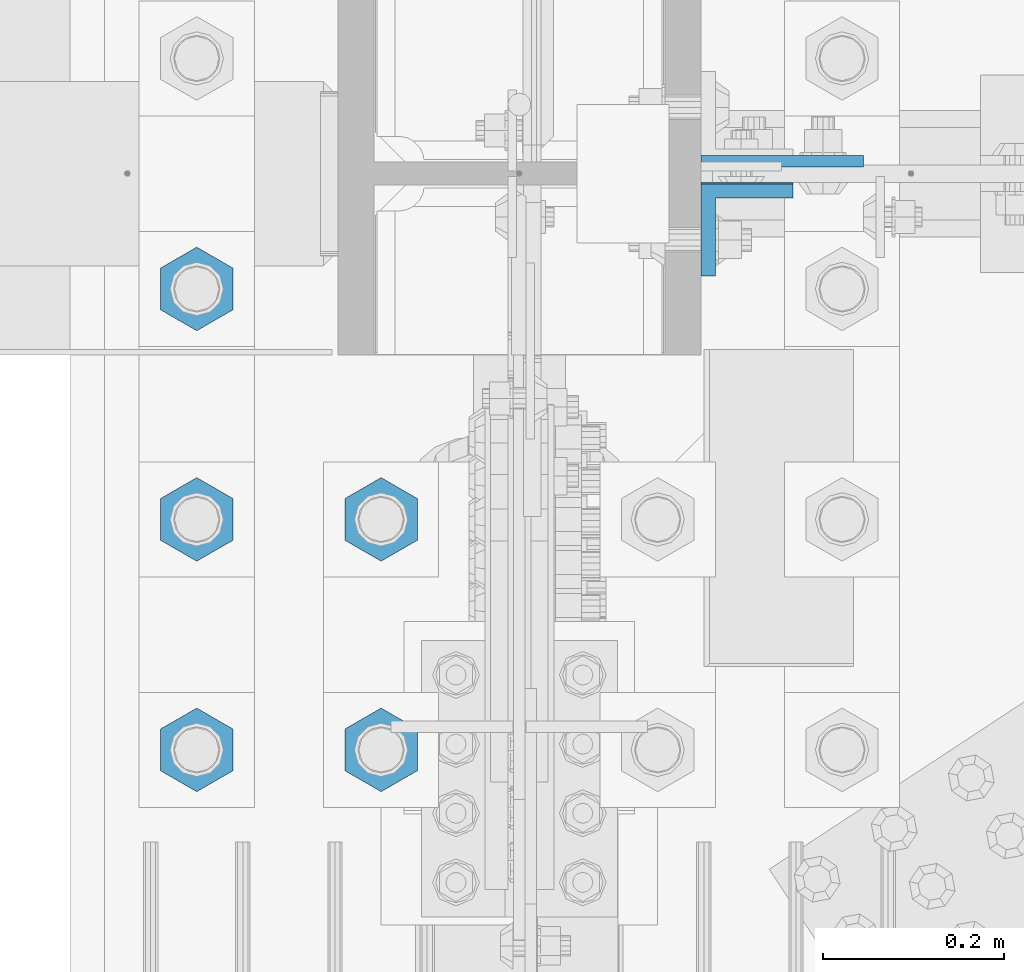
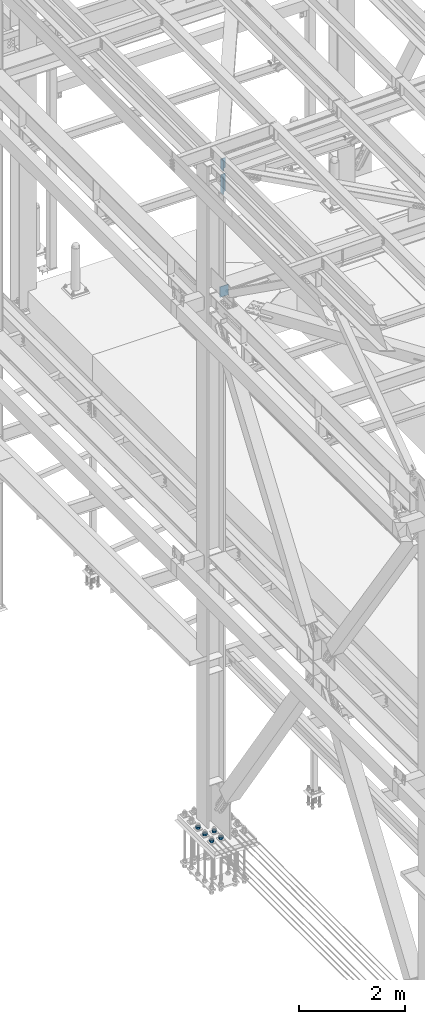
# One storey, part 1553 of 3843: 8 columns, 3 elements without a shape of their own.
"""IFC2X3 building model written with IfcOpenShell, lengths in millimetres."""

from ifc_helpers import new_model, si_unit, frame, origin_with_axes, place, context, subcontext, project, spatial, faceted_brep, material, type_object, element, aggregate, save


model = new_model("IFC2X3")

# Units and contexts
model_context = context("Model", 3, precision=1e-05, world=origin_with_axes())
body_context = subcontext(model_context, "Body", "Model", "MODEL_VIEW")
ifc_project = project(units=[si_unit("LENGTHUNIT", "METRE", prefix="MILLI"), si_unit("AREAUNIT", "SQUARE_METRE"), si_unit("VOLUMEUNIT", "CUBIC_METRE"), si_unit("MASSUNIT", "GRAM", prefix="KILO"), si_unit("TIMEUNIT", "SECOND"), si_unit("PLANEANGLEUNIT", "RADIAN"), si_unit("SOLIDANGLEUNIT", "STERADIAN"), si_unit("THERMODYNAMICTEMPERATUREUNIT", "DEGREE_CELSIUS"), si_unit("LUMINOUSINTENSITYUNIT", "LUMEN")], contexts=[model_context])

# Site, building, storey
site_placement = place(None, origin_with_axes())
site = spatial("IfcSite", under=ifc_project, at=site_placement, CompositionType="ELEMENT")
building_placement = place(site_placement, origin_with_axes())
building = spatial("IfcBuilding", under=site, at=building_placement, Name="Undefined", CompositionType="ELEMENT")
storey_placement = place(building_placement, origin_with_axes())
storey = spatial("IfcBuildingStorey", under=building, at=storey_placement, Name="Undefined", CompositionType="ELEMENT", Elevation=0.0)

# Assembly, columns
assembly_1_placement = place(storey_placement, origin_with_axes())
assembly_1 = element("IfcElementAssembly", 1, at=assembly_1_placement, inside=storey, Name="BEAM", AssemblyPlace="NOTDEFINED", PredefinedType="RIGID_FRAME")
ifc_material = material(Name="STEEL/A572-50")
column_type_1 = type_object("IfcColumnType", Name="L4X4X5/8", PredefinedType="NOTDEFINED")
column_1_placement = place(assembly_1_placement, frame((36826.8249999923, 75566.5879995346, 45113.5417966023), z_axis=(0.0, -1.0, 0.0), x_axis=(0.0, 0.0, 1.0)))
column_1 = element("IfcColumn", 2, at=column_1_placement, type_object=column_type_1, material=ifc_material, Name="ANGLE", ObjectType="L4X4X5/8", context=body_context, shape_type="Brep", body=[
    faceted_brep([(0.0, 50.8000000000029, -50.8000000000029), (0.0, 50.8000000000029, 50.8000000000029), (228.611761594606, 50.8000000000029, 50.8000000000029), (228.611761594606, 50.8000000000029, -50.8000000000029), (0.0, 34.9250000000029, 50.8000000000029), (228.611761594606, 34.9250000000029, 50.8000000000029), (0.0, 34.9250000000029, -34.9250000000029), (228.611761594606, 34.9250000000029, -34.9250000000029), (0.0, -50.8000000000029, -34.9250000000029), (228.611761594606, -50.8000000000029, -34.9250000000029), (0.0, -50.8000000000029, -50.8000000000029), (228.611761594606, -50.8000000000029, -50.8000000000029)], [[[0, 1, 2, 3]], [[1, 4, 5, 2]], [[4, 6, 7, 5]], [[6, 8, 9, 7]], [[8, 10, 11, 9]], [[10, 0, 3, 11]], [[5, 7, 9, 11, 3, 2]], [[10, 8, 6, 4, 1, 0]]]),
])
column_2_placement = place(assembly_1_placement, frame((36826.8249999969, 75568.1750003815, 44571.6187929595), z_axis=(0.0, -1.0, 0.0), x_axis=(0.0, 0.0, 1.0)))
column_2 = element("IfcColumn", 3, at=column_2_placement, type_object=column_type_1, material=ifc_material, Name="ANGLE", ObjectType="L4X4X5/8", context=body_context, shape_type="Brep", body=[
    faceted_brep([(0.0, 50.8000000000029, -50.8000000000029), (0.0, 50.8000000000029, 50.8000000000029), (406.399999999841, 50.799999998344, 50.8000000000029), (406.399999999841, 50.799999998344, -50.8000000000029), (0.0, 34.9250000000029, 50.8000000000029), (406.399999999892, 34.924999998344, 50.8000000000029), (0.0, 34.9250000000029, -34.9250000000029), (406.399999999892, 34.924999998344, -34.9250000000029), (0.0, -50.8000000000029, -34.9250000000029), (406.400000000162, -50.8000000016473, -34.9250000000029), (0.0, -50.8000000000029, -50.8000000000029), (406.400000000162, -50.8000000016473, -50.8000000000029)], [[[0, 1, 2, 3]], [[1, 4, 5, 2]], [[4, 6, 7, 5]], [[6, 8, 9, 7]], [[8, 10, 11, 9]], [[10, 0, 3, 11]], [[5, 7, 9, 11, 3, 2]], [[10, 8, 6, 4, 1, 0]]]),
])
aggregate(assembly_1, [column_1, column_2])

# Assembly, column
assembly_2_placement = place(storey_placement, origin_with_axes())
assembly_2 = element("IfcElementAssembly", 4, at=assembly_2_placement, inside=storey, Name="COLUMN", AssemblyPlace="NOTDEFINED", PredefinedType="RIGID_FRAME")
column_type_2 = type_object("IfcColumnType", PredefinedType="NOTDEFINED")
column_3_placement = place(assembly_2_placement, frame((36865.5849999999, 75641.99375, 42133.6016008451), z_axis=(-1.0, 0.0, 0.0), x_axis=(0.0, 0.0, 1.0)))
column_3 = element("IfcColumn", 5, at=column_3_placement, type_object=column_type_2, material=ifc_material, Name="PLATE", context=body_context, shape_type="Brep", body=[
    faceted_brep([(0.0, 6.34999999999854, -89.5599999999977), (0.0, 6.34999999999854, 89.5599999999977), (241.300000000003, 6.34999999999854, 89.5599999999977), (241.300000000003, 6.34999999999854, -89.5599999999977), (0.0, -6.34999999999854, 89.5599999999977), (241.300000000003, -6.34999999999854, 89.5599999999977), (0.0, -6.34999999999854, -89.5599999999977), (241.300000000003, -6.34999999999854, -89.5599999999977)], [[[0, 1, 2, 3]], [[1, 4, 5, 2]], [[4, 6, 7, 5]], [[6, 0, 3, 7]], [[5, 7, 3, 2]], [[6, 4, 1, 0]]]),
])
aggregate(assembly_2, [column_3])

# Assembly, columns
assembly_3_placement = place(storey_placement, origin_with_axes())
assembly_3 = element("IfcElementAssembly", 6, at=assembly_3_placement, inside=storey, Name="TEMPLATE", AssemblyPlace="NOTDEFINED", PredefinedType="RIGID_FRAME")
column_type_3 = type_object("IfcColumnType", Name="2_HEAVY_HEX_NUT", PredefinedType="NOTDEFINED")
column_4_placement = place(assembly_3_placement, frame((36423.6, 74993.5, 30232.35), z_axis=(1.0, 0.0, 0.0), x_axis=(0.0, 0.0, -1.0)))
column_4 = element("IfcColumn", 7, at=column_4_placement, type_object=column_type_3, material=ifc_material, Name="NUT", ObjectType="2_HEAVY_HEX_NUT", context=body_context, shape_type="Brep", body=[
    faceted_brep([(0.0, -46.0369987487793, 0.0), (0.0, -23.0184993743896, -39.869213104248), (50.7999999999993, -23.0184993743896, -39.869213104248), (50.7999999999993, -46.0369987487793, 0.0), (0.0, 23.0184993743896, -39.869213104248), (50.7999999999993, 23.0184993743896, -39.869213104248), (0.0, 46.0369987487793, 0.0), (50.7999999999993, 46.0369987487793, 0.0), (0.0, 23.0184993743896, 39.869213104248), (50.7999999999993, 23.0184993743896, 39.869213104248), (0.0, -23.0184993743896, 39.869213104248), (50.7999999999993, -23.0184993743896, 39.869213104248), (0.0, 0.0, 26.1940002441406), (0.0, 11.3650617044477, 23.5999013092805), (50.7999999999993, 11.3650617044477, 23.5999013092805), (50.7999999999993, 0.0, 26.1940002441406), (0.0, 20.4791109456419, 16.3316083006721), (50.7999999999993, 20.4791109456419, 16.3316083006721), (0.0, 25.5370200498292, 5.82867859874386), (50.7999999999993, 25.5370200498292, 5.82867859874386), (0.0, 25.5370200498292, -5.82867859874386), (50.7999999999993, 25.5370200498292, -5.82867859874386), (0.0, 20.4791109456419, -16.3316083006721), (50.7999999999993, 20.4791109456419, -16.3316083006721), (0.0, 11.3650617044477, -23.5999013092805), (50.7999999999993, 11.3650617044477, -23.5999013092805), (0.0, 0.0, -26.1940002441406), (50.7999999999993, 0.0, -26.1940002441406), (0.0, -11.3650617044477, -23.5999013092805), (50.7999999999993, -11.3650617044477, -23.5999013092805), (0.0, -20.4791109456419, -16.3316083006721), (50.7999999999993, -20.4791109456419, -16.3316083006721), (0.0, -25.5370200498292, -5.82867859874386), (50.7999999999993, -25.5370200498292, -5.82867859874386), (0.0, -25.5370200498292, 5.82867859874386), (50.7999999999993, -25.5370200498292, 5.82867859874386), (0.0, -20.4791109456419, 16.3316083006721), (50.7999999999993, -20.4791109456419, 16.3316083006721), (0.0, -11.3650617044477, 23.5999013092805), (50.7999999999993, -11.3650617044477, 23.5999013092805)], [[[0, 1, 2, 3]], [[1, 4, 5, 2]], [[4, 6, 7, 5]], [[6, 8, 9, 7]], [[8, 10, 11, 9]], [[10, 0, 3, 11]], [[12, 13, 14, 15]], [[13, 16, 17, 14]], [[16, 18, 19, 17]], [[18, 20, 21, 19]], [[20, 22, 23, 21]], [[22, 24, 25, 23]], [[24, 26, 27, 25]], [[26, 28, 29, 27]], [[28, 30, 31, 29]], [[30, 32, 33, 31]], [[32, 34, 35, 33]], [[34, 36, 37, 35]], [[36, 38, 39, 37]], [[38, 12, 15, 39]], [[5, 7, 9, 11, 3, 2], [17, 19, 21, 23, 25, 27, 29, 31, 33, 35, 37, 39, 15, 14]], [[10, 8, 6, 4, 1, 0], [38, 36, 34, 32, 30, 28, 26, 24, 22, 20, 18, 16, 13, 12]]]),
])
column_5_placement = place(assembly_3_placement, frame((36423.6, 75247.5, 30232.35), z_axis=(1.0, 0.0, 0.0), x_axis=(0.0, 0.0, -1.0)))
column_5 = element("IfcColumn", 8, at=column_5_placement, type_object=column_type_3, material=ifc_material, Name="NUT", ObjectType="2_HEAVY_HEX_NUT", context=body_context, shape_type="Brep", body=[
    faceted_brep([(0.0, -46.0369987487793, 0.0), (0.0, -23.0184993743896, -39.869213104248), (50.7999999999993, -23.0184993743896, -39.869213104248), (50.7999999999993, -46.0369987487793, 0.0), (0.0, 23.0184993743896, -39.869213104248), (50.7999999999993, 23.0184993743896, -39.869213104248), (0.0, 46.0369987487793, 0.0), (50.7999999999993, 46.0369987487793, 0.0), (0.0, 23.0184993743896, 39.869213104248), (50.7999999999993, 23.0184993743896, 39.869213104248), (0.0, -23.0184993743896, 39.869213104248), (50.7999999999993, -23.0184993743896, 39.869213104248), (0.0, 0.0, 26.1940002441406), (0.0, 11.3650617044477, 23.5999013092805), (50.7999999999993, 11.3650617044477, 23.5999013092805), (50.7999999999993, 0.0, 26.1940002441406), (0.0, 20.4791109456419, 16.3316083006721), (50.7999999999993, 20.4791109456419, 16.3316083006721), (0.0, 25.5370200498292, 5.82867859874386), (50.7999999999993, 25.5370200498292, 5.82867859874386), (0.0, 25.5370200498292, -5.82867859874386), (50.7999999999993, 25.5370200498292, -5.82867859874386), (0.0, 20.4791109456419, -16.3316083006721), (50.7999999999993, 20.4791109456419, -16.3316083006721), (0.0, 11.3650617044477, -23.5999013092805), (50.7999999999993, 11.3650617044477, -23.5999013092805), (0.0, 0.0, -26.1940002441406), (50.7999999999993, 0.0, -26.1940002441406), (0.0, -11.3650617044477, -23.5999013092805), (50.7999999999993, -11.3650617044477, -23.5999013092805), (0.0, -20.4791109456419, -16.3316083006721), (50.7999999999993, -20.4791109456419, -16.3316083006721), (0.0, -25.5370200498292, -5.82867859874386), (50.7999999999993, -25.5370200498292, -5.82867859874386), (0.0, -25.5370200498292, 5.82867859874386), (50.7999999999993, -25.5370200498292, 5.82867859874386), (0.0, -20.4791109456419, 16.3316083006721), (50.7999999999993, -20.4791109456419, 16.3316083006721), (0.0, -11.3650617044477, 23.5999013092805), (50.7999999999993, -11.3650617044477, 23.5999013092805)], [[[0, 1, 2, 3]], [[1, 4, 5, 2]], [[4, 6, 7, 5]], [[6, 8, 9, 7]], [[8, 10, 11, 9]], [[10, 0, 3, 11]], [[12, 13, 14, 15]], [[13, 16, 17, 14]], [[16, 18, 19, 17]], [[18, 20, 21, 19]], [[20, 22, 23, 21]], [[22, 24, 25, 23]], [[24, 26, 27, 25]], [[26, 28, 29, 27]], [[28, 30, 31, 29]], [[30, 32, 33, 31]], [[32, 34, 35, 33]], [[34, 36, 37, 35]], [[36, 38, 39, 37]], [[38, 12, 15, 39]], [[5, 7, 9, 11, 3, 2], [17, 19, 21, 23, 25, 27, 29, 31, 33, 35, 37, 39, 15, 14]], [[10, 8, 6, 4, 1, 0], [38, 36, 34, 32, 30, 28, 26, 24, 22, 20, 18, 16, 13, 12]]]),
])
column_6_placement = place(assembly_3_placement, frame((36220.4, 74993.5, 30232.35), z_axis=(1.0, 0.0, 0.0), x_axis=(0.0, 0.0, -1.0)))
column_6 = element("IfcColumn", 9, at=column_6_placement, type_object=column_type_3, material=ifc_material, Name="NUT", ObjectType="2_HEAVY_HEX_NUT", context=body_context, shape_type="Brep", body=[
    faceted_brep([(0.0, -46.0369987487793, 0.0), (0.0, -23.0184993743896, -39.869213104248), (50.7999999999993, -23.0184993743896, -39.869213104248), (50.7999999999993, -46.0369987487793, 0.0), (0.0, 23.0184993743896, -39.869213104248), (50.7999999999993, 23.0184993743896, -39.869213104248), (0.0, 46.0369987487793, 0.0), (50.7999999999993, 46.0369987487793, 0.0), (0.0, 23.0184993743896, 39.869213104248), (50.7999999999993, 23.0184993743896, 39.869213104248), (0.0, -23.0184993743896, 39.869213104248), (50.7999999999993, -23.0184993743896, 39.869213104248), (0.0, 0.0, 26.1940002441406), (0.0, 11.3650617044477, 23.5999013092805), (50.7999999999993, 11.3650617044477, 23.5999013092805), (50.7999999999993, 0.0, 26.1940002441406), (0.0, 20.4791109456419, 16.3316083006721), (50.7999999999993, 20.4791109456419, 16.3316083006721), (0.0, 25.5370200498292, 5.82867859874386), (50.7999999999993, 25.5370200498292, 5.82867859874386), (0.0, 25.5370200498292, -5.82867859874386), (50.7999999999993, 25.5370200498292, -5.82867859874386), (0.0, 20.4791109456419, -16.3316083006721), (50.7999999999993, 20.4791109456419, -16.3316083006721), (0.0, 11.3650617044477, -23.5999013092805), (50.7999999999993, 11.3650617044477, -23.5999013092805), (0.0, 0.0, -26.1940002441406), (50.7999999999993, 0.0, -26.1940002441406), (0.0, -11.3650617044477, -23.5999013092805), (50.7999999999993, -11.3650617044477, -23.5999013092805), (0.0, -20.4791109456419, -16.3316083006721), (50.7999999999993, -20.4791109456419, -16.3316083006721), (0.0, -25.5370200498292, -5.82867859874386), (50.7999999999993, -25.5370200498292, -5.82867859874386), (0.0, -25.5370200498292, 5.82867859874386), (50.7999999999993, -25.5370200498292, 5.82867859874386), (0.0, -20.4791109456419, 16.3316083006721), (50.7999999999993, -20.4791109456419, 16.3316083006721), (0.0, -11.3650617044477, 23.5999013092805), (50.7999999999993, -11.3650617044477, 23.5999013092805)], [[[0, 1, 2, 3]], [[1, 4, 5, 2]], [[4, 6, 7, 5]], [[6, 8, 9, 7]], [[8, 10, 11, 9]], [[10, 0, 3, 11]], [[12, 13, 14, 15]], [[13, 16, 17, 14]], [[16, 18, 19, 17]], [[18, 20, 21, 19]], [[20, 22, 23, 21]], [[22, 24, 25, 23]], [[24, 26, 27, 25]], [[26, 28, 29, 27]], [[28, 30, 31, 29]], [[30, 32, 33, 31]], [[32, 34, 35, 33]], [[34, 36, 37, 35]], [[36, 38, 39, 37]], [[38, 12, 15, 39]], [[5, 7, 9, 11, 3, 2], [17, 19, 21, 23, 25, 27, 29, 31, 33, 35, 37, 39, 15, 14]], [[10, 8, 6, 4, 1, 0], [38, 36, 34, 32, 30, 28, 26, 24, 22, 20, 18, 16, 13, 12]]]),
])
column_7_placement = place(assembly_3_placement, frame((36220.4, 75247.5, 30232.35), z_axis=(1.0, 0.0, 0.0), x_axis=(0.0, 0.0, -1.0)))
column_7 = element("IfcColumn", 10, at=column_7_placement, type_object=column_type_3, material=ifc_material, Name="NUT", ObjectType="2_HEAVY_HEX_NUT", context=body_context, shape_type="Brep", body=[
    faceted_brep([(0.0, -46.0369987487793, 0.0), (0.0, -23.0184993743896, -39.869213104248), (50.7999999999993, -23.0184993743896, -39.869213104248), (50.7999999999993, -46.0369987487793, 0.0), (0.0, 23.0184993743896, -39.869213104248), (50.7999999999993, 23.0184993743896, -39.869213104248), (0.0, 46.0369987487793, 0.0), (50.7999999999993, 46.0369987487793, 0.0), (0.0, 23.0184993743896, 39.869213104248), (50.7999999999993, 23.0184993743896, 39.869213104248), (0.0, -23.0184993743896, 39.869213104248), (50.7999999999993, -23.0184993743896, 39.869213104248), (0.0, 0.0, 26.1940002441406), (0.0, 11.3650617044477, 23.5999013092805), (50.7999999999993, 11.3650617044477, 23.5999013092805), (50.7999999999993, 0.0, 26.1940002441406), (0.0, 20.4791109456419, 16.3316083006721), (50.7999999999993, 20.4791109456419, 16.3316083006721), (0.0, 25.5370200498292, 5.82867859874386), (50.7999999999993, 25.5370200498292, 5.82867859874386), (0.0, 25.5370200498292, -5.82867859874386), (50.7999999999993, 25.5370200498292, -5.82867859874386), (0.0, 20.4791109456419, -16.3316083006721), (50.7999999999993, 20.4791109456419, -16.3316083006721), (0.0, 11.3650617044477, -23.5999013092805), (50.7999999999993, 11.3650617044477, -23.5999013092805), (0.0, 0.0, -26.1940002441406), (50.7999999999993, 0.0, -26.1940002441406), (0.0, -11.3650617044477, -23.5999013092805), (50.7999999999993, -11.3650617044477, -23.5999013092805), (0.0, -20.4791109456419, -16.3316083006721), (50.7999999999993, -20.4791109456419, -16.3316083006721), (0.0, -25.5370200498292, -5.82867859874386), (50.7999999999993, -25.5370200498292, -5.82867859874386), (0.0, -25.5370200498292, 5.82867859874386), (50.7999999999993, -25.5370200498292, 5.82867859874386), (0.0, -20.4791109456419, 16.3316083006721), (50.7999999999993, -20.4791109456419, 16.3316083006721), (0.0, -11.3650617044477, 23.5999013092805), (50.7999999999993, -11.3650617044477, 23.5999013092805)], [[[0, 1, 2, 3]], [[1, 4, 5, 2]], [[4, 6, 7, 5]], [[6, 8, 9, 7]], [[8, 10, 11, 9]], [[10, 0, 3, 11]], [[12, 13, 14, 15]], [[13, 16, 17, 14]], [[16, 18, 19, 17]], [[18, 20, 21, 19]], [[20, 22, 23, 21]], [[22, 24, 25, 23]], [[24, 26, 27, 25]], [[26, 28, 29, 27]], [[28, 30, 31, 29]], [[30, 32, 33, 31]], [[32, 34, 35, 33]], [[34, 36, 37, 35]], [[36, 38, 39, 37]], [[38, 12, 15, 39]], [[5, 7, 9, 11, 3, 2], [17, 19, 21, 23, 25, 27, 29, 31, 33, 35, 37, 39, 15, 14]], [[10, 8, 6, 4, 1, 0], [38, 36, 34, 32, 30, 28, 26, 24, 22, 20, 18, 16, 13, 12]]]),
])
column_8_placement = place(assembly_3_placement, frame((36220.4, 75501.5, 30232.35), z_axis=(1.0, 0.0, 0.0), x_axis=(0.0, 0.0, -1.0)))
column_8 = element("IfcColumn", 11, at=column_8_placement, type_object=column_type_3, material=ifc_material, Name="NUT", ObjectType="2_HEAVY_HEX_NUT", context=body_context, shape_type="Brep", body=[
    faceted_brep([(0.0, -46.0369987487793, 0.0), (0.0, -23.0184993743896, -39.869213104248), (50.7999999999993, -23.0184993743896, -39.869213104248), (50.7999999999993, -46.0369987487793, 0.0), (0.0, 23.0184993743896, -39.869213104248), (50.7999999999993, 23.0184993743896, -39.869213104248), (0.0, 46.0369987487793, 0.0), (50.7999999999993, 46.0369987487793, 0.0), (0.0, 23.0184993743896, 39.869213104248), (50.7999999999993, 23.0184993743896, 39.869213104248), (0.0, -23.0184993743896, 39.869213104248), (50.7999999999993, -23.0184993743896, 39.869213104248), (0.0, 0.0, 26.1940002441406), (0.0, 11.3650617044477, 23.5999013092805), (50.7999999999993, 11.3650617044477, 23.5999013092805), (50.7999999999993, 0.0, 26.1940002441406), (0.0, 20.4791109456419, 16.3316083006721), (50.7999999999993, 20.4791109456419, 16.3316083006721), (0.0, 25.5370200498292, 5.82867859874386), (50.7999999999993, 25.5370200498292, 5.82867859874386), (0.0, 25.5370200498292, -5.82867859874386), (50.7999999999993, 25.5370200498292, -5.82867859874386), (0.0, 20.4791109456419, -16.3316083006721), (50.7999999999993, 20.4791109456419, -16.3316083006721), (0.0, 11.3650617044477, -23.5999013092805), (50.7999999999993, 11.3650617044477, -23.5999013092805), (0.0, 0.0, -26.1940002441406), (50.7999999999993, 0.0, -26.1940002441406), (0.0, -11.3650617044477, -23.5999013092805), (50.7999999999993, -11.3650617044477, -23.5999013092805), (0.0, -20.4791109456419, -16.3316083006721), (50.7999999999993, -20.4791109456419, -16.3316083006721), (0.0, -25.5370200498292, -5.82867859874386), (50.7999999999993, -25.5370200498292, -5.82867859874386), (0.0, -25.5370200498292, 5.82867859874386), (50.7999999999993, -25.5370200498292, 5.82867859874386), (0.0, -20.4791109456419, 16.3316083006721), (50.7999999999993, -20.4791109456419, 16.3316083006721), (0.0, -11.3650617044477, 23.5999013092805), (50.7999999999993, -11.3650617044477, 23.5999013092805)], [[[0, 1, 2, 3]], [[1, 4, 5, 2]], [[4, 6, 7, 5]], [[6, 8, 9, 7]], [[8, 10, 11, 9]], [[10, 0, 3, 11]], [[12, 13, 14, 15]], [[13, 16, 17, 14]], [[16, 18, 19, 17]], [[18, 20, 21, 19]], [[20, 22, 23, 21]], [[22, 24, 25, 23]], [[24, 26, 27, 25]], [[26, 28, 29, 27]], [[28, 30, 31, 29]], [[30, 32, 33, 31]], [[32, 34, 35, 33]], [[34, 36, 37, 35]], [[36, 38, 39, 37]], [[38, 12, 15, 39]], [[5, 7, 9, 11, 3, 2], [17, 19, 21, 23, 25, 27, 29, 31, 33, 35, 37, 39, 15, 14]], [[10, 8, 6, 4, 1, 0], [38, 36, 34, 32, 30, 28, 26, 24, 22, 20, 18, 16, 13, 12]]]),
])
aggregate(assembly_3, [column_4, column_5, column_6, column_7, column_8])

save(model, "model.ifc")
